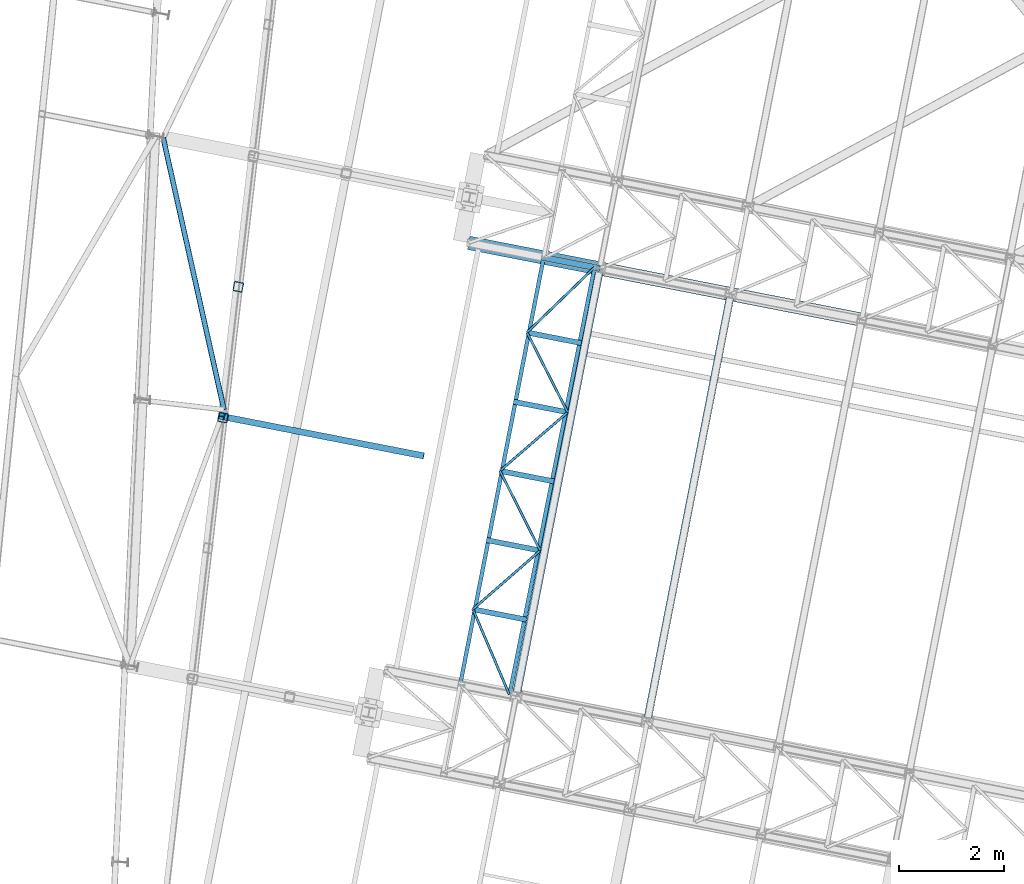
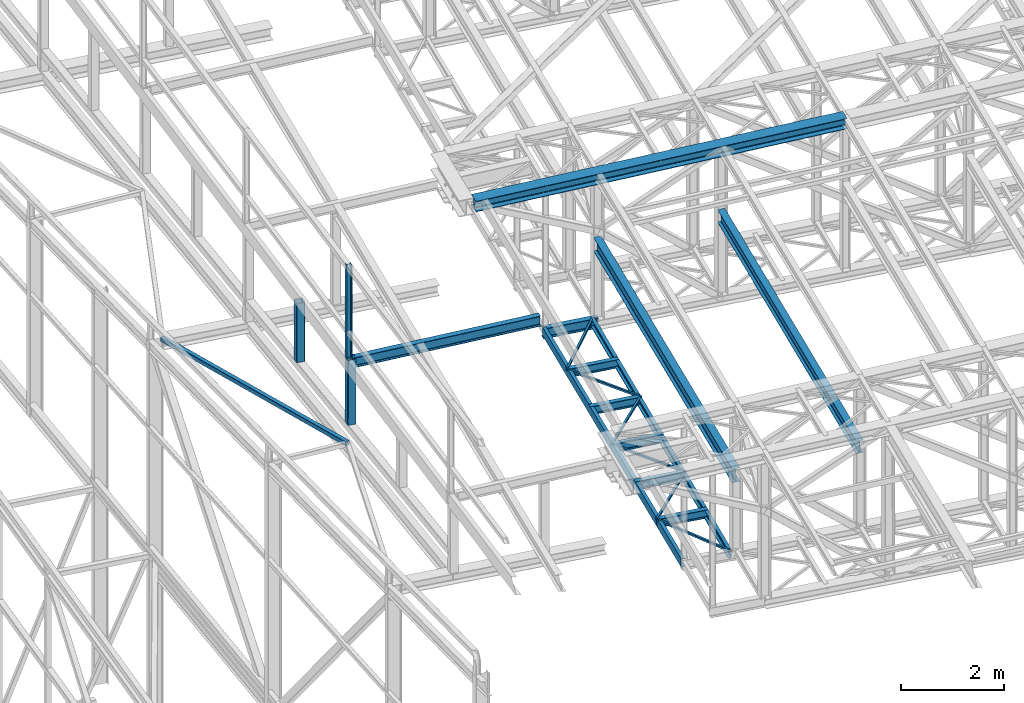
# One storey, part 43 of 215: 22 beams, 22 elements without a shape of their own.
"""IFC2X3 building model written with IfcOpenShell, lengths in millimetres."""

from ifc_helpers import new_model, si_unit, frame, origin_with_axes, origin_2d_with_axis, place, context, subcontext, project, spatial, hollow_rectangle, i_section, u_section, extrude, clip, halfspace, material, type_object, element, aggregate, save


model = new_model("IFC2X3")

# Units and contexts
model_context = context("Model", 3, precision=1e-05, world=origin_with_axes())
body_context = subcontext(model_context, "Body", "Model", "MODEL_VIEW")
ifc_project = project(units=[si_unit("LENGTHUNIT", "METRE", prefix="MILLI"), si_unit("AREAUNIT", "SQUARE_METRE"), si_unit("VOLUMEUNIT", "CUBIC_METRE"), si_unit("MASSUNIT", "GRAM", prefix="KILO"), si_unit("TIMEUNIT", "SECOND"), si_unit("PLANEANGLEUNIT", "RADIAN"), si_unit("SOLIDANGLEUNIT", "STERADIAN"), si_unit("THERMODYNAMICTEMPERATUREUNIT", "DEGREE_CELSIUS"), si_unit("LUMINOUSINTENSITYUNIT", "LUMEN")], contexts=[model_context])

# Site, building, storey
site_placement = place(None, origin_with_axes())
site = spatial("IfcSite", under=ifc_project, at=site_placement, CompositionType="ELEMENT")
building_placement = place(site_placement, origin_with_axes())
building = spatial("IfcBuilding", under=site, at=building_placement, Name="Undefined", CompositionType="ELEMENT")
storey_placement = place(building_placement, origin_with_axes())
storey = spatial("IfcBuildingStorey", under=building, at=storey_placement, Name="Undefined", CompositionType="ELEMENT", Elevation=0.0)

# Assembly, beam
assembly_1_placement = place(storey_placement, origin_with_axes())
assembly_1 = element("IfcElementAssembly", 1, at=assembly_1_placement, inside=storey, Name="Steel Assembly", AssemblyPlace="NOTDEFINED", PredefinedType="RIGID_FRAME")
ifc_material_1 = material(Name="STEEL/S355JR")
beam_type_1 = type_object("IfcBeamType", Name="IPE240", PredefinedType="NOTDEFINED")
beam_1_placement = place(assembly_1_placement, frame((45544.5586696769, 31857.4707559464, 8619.99999999768), z_axis=(0.0, 0.0, 1.0), x_axis=(0.981422409205525, -0.19185946604018, 1.89999991602007e-08)))
beam_1 = element("IfcBeam", 2, at=beam_1_placement, type_object=beam_type_1, material=ifc_material_1, ObjectType="IPE240", context=body_context, shape_type="SweptSolid", body=[
    extrude(i_section(OverallWidth=120.0, OverallDepth=240.0, WebThickness=6.199999809, FlangeThickness=9.800000191, FilletRadius=15.0, at=origin_2d_with_axis()), frame((1125.79486349449, 0.0, 0.0), z_axis=(-1.0, 0.0, 0.0), x_axis=(-6.93889390390723e-18, -1.0, -3.46944695195361e-18)), (0.0, 0.0, 1.0), 1125.8),
])
aggregate(assembly_1, [beam_1])

assembly_2_placement = place(storey_placement, origin_with_axes())
assembly_2 = element("IfcElementAssembly", 3, at=assembly_2_placement, inside=storey, Name="Steel Assembly", AssemblyPlace="NOTDEFINED", PredefinedType="RIGID_FRAME")
ifc_material_2 = material(Name="STEEL/S275JR")
beam_2_placement = place(assembly_2_placement, frame((39390.3962023619, 28832.8524973766, 11886.0187981017), z_axis=(-0.0304080349967745, 0.00594450299936818, 0.999519891893966), x_axis=(0.980951223231219, -0.191767338045201, 0.0309836360073031)))
beam_2 = element("IfcBeam", 4, at=beam_2_placement, type_object=beam_type_1, material=ifc_material_2, Name="TRAVERSE", ObjectType="IPE240", context=body_context, shape_type="SweptSolid", body=[
    extrude(i_section(OverallWidth=120.0, OverallDepth=240.0, WebThickness=6.199999809, FlangeThickness=9.800000191, FilletRadius=15.0, at=origin_2d_with_axis()), frame((3981.40487221962, -1.02714526831027e-13, -1.79136285754903e-12), z_axis=(-1.0, 0.0, 0.0), x_axis=(-6.93889390390723e-18, -1.0, -3.46944695195361e-18)), (0.0, 0.0, 1.0), 3981.4),
])
aggregate(assembly_2, [beam_2])

assembly_3_placement = place(storey_placement, origin_with_axes())
assembly_3 = element("IfcElementAssembly", 5, at=assembly_3_placement, inside=storey, Name="Steel Assembly", AssemblyPlace="NOTDEFINED", PredefinedType="RIGID_FRAME")
beam_type_2 = type_object("IfcBeamType", PredefinedType="NOTDEFINED")
beam_3_placement = place(assembly_3_placement, frame((38329.7469281126, 34132.8784085332, 9619.916786054), z_axis=(0.975916895261586, 0.217524361058308, -0.0164123700043992), x_axis=(0.218066762939199, -0.974796631728206, 0.0471000389868677)))
beam_3 = element("IfcBeam", 6, at=beam_3_placement, type_object=beam_type_2, material=ifc_material_2, context=body_context, shape_type="SweptSolid", body=[
    extrude(hollow_rectangle(XDim=100.0, YDim=100.0, WallThickness=5.0, InnerFilletRadius=5.0, OuterFilletRadius=10.0, at=origin_2d_with_axis()), frame((5318.61377056941, 1.78208410687602e-12, -3.05621988047122e-14), z_axis=(-1.0, 0.0, 0.0), x_axis=(-6.93889390390723e-18, -1.0, -3.46944695195361e-18)), (0.0, 0.0, 1.0), 5318.6),
])
aggregate(assembly_3, [beam_3])

assembly_4_placement = place(storey_placement, origin_with_axes())
assembly_4 = element("IfcElementAssembly", 7, at=assembly_4_placement, inside=storey, Name="Steel Assembly", AssemblyPlace="NOTDEFINED", PredefinedType="RIGID_FRAME")
beam_type_3 = type_object("IfcBeamType", PredefinedType="NOTDEFINED")
beam_4_placement = place(assembly_4_placement, frame((44232.8650283521, 25147.8197383188, 8715.68808127638), z_axis=(0.0, 0.0, -1.0), x_axis=(0.392413519067678, -0.919788905158635, 0.0)))
beam_4 = element("IfcBeam", 8, at=beam_4_placement, type_object=beam_type_3, material=ifc_material_2, context=body_context, shape_type="SweptSolid", body=[
    extrude(hollow_rectangle(XDim=50.0, YDim=50.0, WallThickness=3.0, InnerFilletRadius=3.0, OuterFilletRadius=6.0, at=origin_2d_with_axis()), frame((1768.40075132733, 0.0, 0.0), z_axis=(-1.0, 0.0, 0.0), x_axis=(-6.93889390390723e-18, -1.0, -3.46944695195361e-18)), (0.0, 0.0, 1.0), 1768.4),
])
aggregate(assembly_4, [beam_4])

assembly_5_placement = place(storey_placement, origin_with_axes())
assembly_5 = element("IfcElementAssembly", 9, at=assembly_5_placement, inside=storey, Name="Steel Assembly", AssemblyPlace="NOTDEFINED", PredefinedType="RIGID_FRAME")
beam_5_placement = place(assembly_5_placement, frame((45514.6902231664, 26265.9935730251, 8715.68808127638), z_axis=(0.0, 0.0, -1.0), x_axis=(-0.753573164058399, -0.657364044050946, 0.0)))
beam_5 = element("IfcBeam", 10, at=beam_5_placement, type_object=beam_type_3, material=ifc_material_2, context=body_context, shape_type="SweptSolid", body=[
    extrude(hollow_rectangle(XDim=50.0, YDim=50.0, WallThickness=3.0, InnerFilletRadius=3.0, OuterFilletRadius=6.0, at=origin_2d_with_axis()), frame((1700.99634170737, 3.77697060673333e-13, 0.0), z_axis=(-1.0, 0.0, 0.0), x_axis=(-6.93889390390723e-18, -1.0, -3.46944695195361e-18)), (0.0, 0.0, 1.0), 1701.0),
])
aggregate(assembly_5, [beam_5])

assembly_6_placement = place(storey_placement, origin_with_axes())
assembly_6 = element("IfcElementAssembly", 11, at=assembly_6_placement, inside=storey, Name="Steel Assembly", AssemblyPlace="NOTDEFINED", PredefinedType="RIGID_FRAME")
beam_6_placement = place(assembly_6_placement, frame((44748.3306575184, 27784.5723727106, 8715.68808126931), z_axis=(0.0, 0.0, -1.0), x_axis=(0.450535692998692, -0.892758415997401, 0.0)))
beam_6 = element("IfcBeam", 12, at=beam_6_placement, type_object=beam_type_3, material=ifc_material_2, context=body_context, shape_type="SweptSolid", body=[
    extrude(hollow_rectangle(XDim=50.0, YDim=50.0, WallThickness=3.0, InnerFilletRadius=3.0, OuterFilletRadius=6.0, at=origin_2d_with_axis()), frame((1700.99634170737, 3.77697060673333e-13, 0.0), z_axis=(-1.0, 0.0, 0.0), x_axis=(-6.93889390390723e-18, -1.0, -3.46944695195361e-18)), (0.0, 0.0, 1.0), 1701.0),
])
aggregate(assembly_6, [beam_6])

assembly_7_placement = place(storey_placement, origin_with_axes())
assembly_7 = element("IfcElementAssembly", 13, at=assembly_7_placement, inside=storey, Name="Steel Assembly", AssemblyPlace="NOTDEFINED", PredefinedType="RIGID_FRAME")
beam_7_placement = place(assembly_7_placement, frame((46038.5998007224, 28901.0954779881, 8715.68808126934), z_axis=(0.0, 0.0, -1.0), x_axis=(-0.756184910996357, -0.654357990996849, 0.0)))
beam_7 = element("IfcBeam", 14, at=beam_7_placement, type_object=beam_type_3, material=ifc_material_2, context=body_context, shape_type="SweptSolid", body=[
    extrude(hollow_rectangle(XDim=50.0, YDim=50.0, WallThickness=3.0, InnerFilletRadius=3.0, OuterFilletRadius=6.0, at=origin_2d_with_axis()), frame((1706.28787331128, -1.53483539100752e-12, 0.0), z_axis=(-1.0, 0.0, 0.0), x_axis=(-6.93889390390723e-18, -1.0, -3.46944695195361e-18)), (0.0, 0.0, 1.0), 1706.3),
])
aggregate(assembly_7, [beam_7])

assembly_8_placement = place(storey_placement, origin_with_axes())
assembly_8 = element("IfcElementAssembly", 15, at=assembly_8_placement, inside=storey, Name="Steel Assembly", AssemblyPlace="NOTDEFINED", PredefinedType="RIGID_FRAME")
beam_8_placement = place(assembly_8_placement, frame((45263.7962866848, 30421.3250071021, 8715.68808126225), z_axis=(0.0, 0.0, -1.0), x_axis=(0.454087218065015, -0.89095723712756, 0.0)))
beam_8 = element("IfcBeam", 16, at=beam_8_placement, type_object=beam_type_3, material=ifc_material_2, context=body_context, shape_type="SweptSolid", body=[
    extrude(hollow_rectangle(XDim=50.0, YDim=50.0, WallThickness=3.0, InnerFilletRadius=3.0, OuterFilletRadius=6.0, at=origin_2d_with_axis()), frame((1706.28787331128, -1.53483539100752e-12, 0.0), z_axis=(-1.0, 0.0, 0.0), x_axis=(-6.93889390390723e-18, -1.0, -3.46944695195361e-18)), (0.0, 0.0, 1.0), 1706.3),
])
aggregate(assembly_8, [beam_8])

assembly_9_placement = place(storey_placement, origin_with_axes())
assembly_9 = element("IfcElementAssembly", 17, at=assembly_9_placement, inside=storey, Name="Steel Assembly", AssemblyPlace="NOTDEFINED", PredefinedType="RIGID_FRAME")
beam_9_placement = place(assembly_9_placement, frame((46548.8650694623, 31661.1320994037, 8715.68808126218), z_axis=(0.0, 0.0, -1.0), x_axis=(-0.71966696784498, -0.69431941885044, 0.0)))
beam_9 = element("IfcBeam", 18, at=beam_9_placement, type_object=beam_type_3, material=ifc_material_2, context=body_context, shape_type="SweptSolid", body=[
    extrude(hollow_rectangle(XDim=50.0, YDim=50.0, WallThickness=3.0, InnerFilletRadius=3.0, OuterFilletRadius=6.0, at=origin_2d_with_axis()), frame((1785.64369413783, -1.81898940354586e-12, 0.0), z_axis=(-1.0, 0.0, 0.0), x_axis=(-6.93889390390723e-18, -1.0, -3.46944695195361e-18)), (0.0, 0.0, 1.0), 1785.6),
])
aggregate(assembly_9, [beam_9])

assembly_10_placement = place(storey_placement, origin_with_axes())
assembly_10 = element("IfcElementAssembly", 19, at=assembly_10_placement, inside=storey, Name="Steel Assembly", AssemblyPlace="NOTDEFINED", PredefinedType="RIGID_FRAME")
beam_type_4 = type_object("IfcBeamType", Name="UPN200", PredefinedType="NOTDEFINED")
beam_10_placement = place(assembly_10_placement, frame((45581.3555770996, 31850.2772905966, 8640.68808129229), z_axis=(0.0, 0.0, -1.0), x_axis=(-0.191860814904866, -0.981422145513357, 0.0)))
beam_10 = element("IfcBeam", 20, at=beam_10_placement, type_object=beam_type_4, material=ifc_material_2, ObjectType="UPN200", context=body_context, shape_type="SweptSolid", body=[
    extrude(u_section(Depth=200.0, FlangeWidth=75.0, WebThickness=8.5, FlangeThickness=11.5, FilletRadius=11.5, EdgeRadius=6.0, FlangeSlope=0.0798299857122373, at=origin_2d_with_axis()), frame((8299.99520183324, 7.50632875861727e-12, -1.81898940354586e-12), z_axis=(-1.0, 0.0, 0.0), x_axis=(-6.93889390390723e-18, -1.0, -3.46944695195361e-18)), (0.0, 0.0, 1.0), 8300.0),
])
aggregate(assembly_10, [beam_10])

assembly_11_placement = place(storey_placement, origin_with_axes())
assembly_11 = element("IfcElementAssembly", 21, at=assembly_11_placement, inside=storey, Name="Steel Assembly", AssemblyPlace="NOTDEFINED", PredefinedType="RIGID_FRAME")
beam_11_placement = place(assembly_11_placement, frame((44930.9789326412, 23520.4412726233, 8640.6880812835), z_axis=(0.0, 0.0, -1.0), x_axis=(0.195171766899161, 0.980769076493269, 0.0)))
beam_11 = element("IfcBeam", 22, at=beam_11_placement, type_object=beam_type_4, material=ifc_material_2, ObjectType="UPN200", context=body_context, shape_type="SweptSolid", body=[
    extrude(u_section(Depth=200.0, FlangeWidth=75.0, WebThickness=8.5, FlangeThickness=11.5, FilletRadius=11.5, EdgeRadius=6.0, FlangeSlope=0.0798299857122373, at=origin_2d_with_axis()), frame((8299.89954560705, -2.3036848944022e-13, 0.0), z_axis=(-1.0, 0.0, 0.0), x_axis=(-6.93889390390723e-18, -1.0, -3.46944695195361e-18)), (0.0, 0.0, 1.0), 8299.9),
])
aggregate(assembly_11, [beam_11])

assembly_12_placement = place(storey_placement, origin_with_axes())
assembly_12 = element("IfcElementAssembly", 23, at=assembly_12_placement, inside=storey, Name="Steel Assembly", AssemblyPlace="NOTDEFINED", PredefinedType="RIGID_FRAME")
beam_type_5 = type_object("IfcBeamType", PredefinedType="NOTDEFINED")
beam_12_placement = place(assembly_12_placement, frame((39761.4727832382, 31291.9300104335, 11736.8686248737), z_axis=(-0.981422412140383, 0.191859451027444, 0.0), x_axis=(0.0, 0.0, -1.0)))
beam_12 = element("IfcBeam", 24, at=beam_12_placement, type_object=beam_type_5, material=ifc_material_2, Name="MONTANT", context=body_context, shape_type="Clipping", body=[
    clip(extrude(hollow_rectangle(XDim=180.0, YDim=180.0, WallThickness=8.0, InnerFilletRadius=12.0, OuterFilletRadius=20.0, at=origin_2d_with_axis()), frame((1405.59182170057, 0.0, 0.0), z_axis=(-1.0, 0.0, 0.0), x_axis=(-6.93889390390723e-18, -1.0, -3.46944695195361e-18)), (0.0, 0.0, 1.0), 1405.6), halfspace(frame((1408.63968319935, -151.148204456535, 101.765882453423), z_axis=(-0.99875033817135, -0.0498277907891155, 0.00386694552461437), x_axis=(0.0, -0.0773735506072624, -0.997002173350904)), True)),
])
aggregate(assembly_12, [beam_12])

assembly_13_placement = place(storey_placement, origin_with_axes())
assembly_13 = element("IfcElementAssembly", 25, at=assembly_13_placement, inside=storey, Name="Steel Assembly", AssemblyPlace="NOTDEFINED", PredefinedType="RIGID_FRAME")
beam_13_placement = place(assembly_13_placement, frame((39472.4782659299, 28801.0394779885, 11976.1490847472), z_axis=(-0.981422412140383, 0.191859451027444, 0.0), x_axis=(0.0, 0.0, -1.0)))
beam_13 = element("IfcBeam", 26, at=beam_13_placement, type_object=beam_type_5, material=ifc_material_2, Name="MONTANT", context=body_context, shape_type="Clipping", body=[
    clip(clip(extrude(hollow_rectangle(XDim=180.0, YDim=180.0, WallThickness=8.0, InnerFilletRadius=12.0, OuterFilletRadius=20.0, at=origin_2d_with_axis()), frame((1514.50469071019, 0.0, 0.0), z_axis=(-1.0, 0.0, 0.0), x_axis=(-6.93889390390723e-18, -1.0, -3.46944695195361e-18)), (0.0, 0.0, 1.0), 1551.6), halfspace(frame((1523.69820856424, -176.206894575029, 103.965464390218), z_axis=(-0.99875033817135, -0.0498277907891155, 0.00386694552461437), x_axis=(0.0, -0.0773735506072624, -0.997002173350904)), True)), halfspace(frame((-37.4295460500798, 157.566234099264, 84.2397413081562), z_axis=(0.999997034433376, 0.00242814009745113, -0.000187776786755893), x_axis=(0.0, -0.0771033742924094, -0.997023103881111)), True)),
])
aggregate(assembly_13, [beam_13])

assembly_14_placement = place(storey_placement, origin_with_axes())
assembly_14 = element("IfcElementAssembly", 27, at=assembly_14_placement, inside=storey, Name="Steel Assembly", AssemblyPlace="NOTDEFINED", PredefinedType="RIGID_FRAME")
beam_type_6 = type_object("IfcBeamType", Name="HEA120", PredefinedType="NOTDEFINED")
beam_14_placement = place(assembly_14_placement, frame((39438.9912074627, 28823.4326067669, 14219.9969931652), z_axis=(0.981422409205525, -0.19185946604018, 1.89999991602007e-08), x_axis=(0.0, 0.0, -1.0)))
beam_14 = element("IfcBeam", 28, at=beam_14_placement, type_object=beam_type_6, material=ifc_material_2, ObjectType="HEA120", context=body_context, shape_type="SweptSolid", body=[
    extrude(i_section(OverallWidth=120.0, OverallDepth=114.0, WebThickness=5.0, FlangeThickness=8.0, FilletRadius=12.0, at=origin_2d_with_axis()), frame((2213.77432796867, 0.0, -7.32476481865318e-21), z_axis=(-1.0, 0.0, 0.0), x_axis=(-6.93889390390723e-18, -1.0, -3.46944695195361e-18)), (0.0, 0.0, 1.0), 2213.8),
])
aggregate(assembly_14, [beam_14])

assembly_15_placement = place(storey_placement, origin_with_axes())
assembly_15 = element("IfcElementAssembly", 29, at=assembly_15_placement, inside=storey, Name="Steel Assembly", AssemblyPlace="NOTDEFINED", PredefinedType="RIGID_FRAME")
beam_type_7 = type_object("IfcBeamType", Name="IPE300", PredefinedType="NOTDEFINED")
beam_15_placement = place(assembly_15_placement, frame((47553.2305736091, 23007.6851341911, 10567.0900002997), z_axis=(0.0, 0.0, 1.0), x_axis=(0.191859470081235, 0.981422408415534, 0.0)))
beam_15 = element("IfcBeam", 30, at=beam_15_placement, type_object=beam_type_7, material=ifc_material_2, Name="SUPPORT", ObjectType="IPE300", context=body_context, shape_type="SweptSolid", body=[
    extrude(i_section(OverallWidth=150.0, OverallDepth=300.0, WebThickness=7.099999905, FlangeThickness=10.69999981, FilletRadius=15.0, at=origin_2d_with_axis()), frame((8299.99526300685, 1.47838788079098e-11, -1.71639879146031e-21), z_axis=(-1.0, 0.0, 0.0), x_axis=(-6.93889390390723e-18, -1.0, -3.46944695195361e-18)), (0.0, 0.0, 1.0), 8300.0),
])
aggregate(assembly_15, [beam_15])

assembly_16_placement = place(storey_placement, origin_with_axes())
assembly_16 = element("IfcElementAssembly", 31, at=assembly_16_placement, inside=storey, Name="Steel Assembly", AssemblyPlace="NOTDEFINED", PredefinedType="RIGID_FRAME")
beam_type_8 = type_object("IfcBeamType", Name="IPE200", PredefinedType="NOTDEFINED")
beam_16_placement = place(assembly_16_placement, frame((45252.7354343881, 24948.4426205438, 8640.68808127995), z_axis=(0.0, 0.0, -1.0), x_axis=(-0.981422136295317, 0.191860862057732, 0.0)))
beam_16 = element("IfcBeam", 32, at=beam_16_placement, type_object=beam_type_8, material=ifc_material_2, ObjectType="IPE200", context=body_context, shape_type="SweptSolid", body=[
    extrude(i_section(OverallWidth=100.0, OverallDepth=200.0, WebThickness=5.599999905, FlangeThickness=8.5, FilletRadius=12.0, at=origin_2d_with_axis()), frame((1039.17605831378, -7.27595761418343e-12, -1.81898940354586e-12), z_axis=(-1.0, 0.0, 0.0), x_axis=(-6.93889390390723e-18, -1.0, -3.46944695195361e-18)), (0.0, 0.0, 1.0), 1039.2),
])
aggregate(assembly_16, [beam_16])

assembly_17_placement = place(storey_placement, origin_with_axes())
assembly_17 = element("IfcElementAssembly", 33, at=assembly_17_placement, inside=storey, Name="Steel Assembly", AssemblyPlace="NOTDEFINED", PredefinedType="RIGID_FRAME")
beam_17_placement = place(assembly_17_placement, frame((45514.6902231661, 26265.9935730253, 8640.68808127643), z_axis=(0.0, 0.0, -1.0), x_axis=(-0.981422136295317, 0.191860862057732, 0.0)))
beam_17 = element("IfcBeam", 34, at=beam_17_placement, type_object=beam_type_8, material=ifc_material_2, ObjectType="IPE200", context=body_context, shape_type="SweptSolid", body=[
    extrude(i_section(OverallWidth=100.0, OverallDepth=200.0, WebThickness=5.599999905, FlangeThickness=8.5, FilletRadius=12.0, at=origin_2d_with_axis()), frame((1043.47795243299, 0.0, 1.81898940354586e-12), z_axis=(-1.0, 0.0, 0.0), x_axis=(-6.93889390390723e-18, -1.0, -3.46944695195361e-18)), (0.0, 0.0, 1.0), 1043.5),
])
aggregate(assembly_17, [beam_17])

assembly_18_placement = place(storey_placement, origin_with_axes())
assembly_18 = element("IfcElementAssembly", 35, at=assembly_18_placement, inside=storey, Name="Steel Assembly", AssemblyPlace="NOTDEFINED", PredefinedType="RIGID_FRAME")
beam_18_placement = place(assembly_18_placement, frame((45776.6450119442, 27583.5445255068, 8640.68808127291), z_axis=(0.0, 0.0, -1.0), x_axis=(-0.981422136295317, 0.191860862057732, 0.0)))
beam_18 = element("IfcBeam", 36, at=beam_18_placement, type_object=beam_type_8, material=ifc_material_2, ObjectType="IPE200", context=body_context, shape_type="SweptSolid", body=[
    extrude(i_section(OverallWidth=100.0, OverallDepth=200.0, WebThickness=5.599999905, FlangeThickness=8.5, FilletRadius=12.0, at=origin_2d_with_axis()), frame((1047.77984655224, 2.90817327595128e-14, 1.81898940354586e-12), z_axis=(-1.0, 0.0, 0.0), x_axis=(-6.93889390390723e-18, -1.0, -3.46944695195361e-18)), (0.0, 0.0, 1.0), 1047.8),
])
aggregate(assembly_18, [beam_18])

assembly_19_placement = place(storey_placement, origin_with_axes())
assembly_19 = element("IfcElementAssembly", 37, at=assembly_19_placement, inside=storey, Name="Steel Assembly", AssemblyPlace="NOTDEFINED", PredefinedType="RIGID_FRAME")
beam_19_placement = place(assembly_19_placement, frame((46038.5998007222, 28901.0954779883, 8640.6880812694), z_axis=(0.0, 0.0, -1.0), x_axis=(-0.981422136295317, 0.191860862057732, 0.0)))
beam_19 = element("IfcBeam", 38, at=beam_19_placement, type_object=beam_type_8, material=ifc_material_2, ObjectType="IPE200", context=body_context, shape_type="SweptSolid", body=[
    extrude(i_section(OverallWidth=100.0, OverallDepth=200.0, WebThickness=5.599999905, FlangeThickness=8.5, FilletRadius=12.0, at=origin_2d_with_axis()), frame((1052.08174068533, 0.0, 0.0), z_axis=(-1.0, 0.0, 0.0), x_axis=(-6.93889390390723e-18, -1.0, -3.46944695195361e-18)), (0.0, 0.0, 1.0), 1052.1),
])
aggregate(assembly_19, [beam_19])

assembly_20_placement = place(storey_placement, origin_with_axes())
assembly_20 = element("IfcElementAssembly", 39, at=assembly_20_placement, inside=storey, Name="Steel Assembly", AssemblyPlace="NOTDEFINED", PredefinedType="RIGID_FRAME")
beam_20_placement = place(assembly_20_placement, frame((46300.5545894992, 30218.64643047, 8640.68808126587), z_axis=(0.0, 0.0, -1.0), x_axis=(-0.981422136295317, 0.191860862057732, 0.0)))
beam_20 = element("IfcBeam", 40, at=beam_20_placement, type_object=beam_type_8, material=ifc_material_2, ObjectType="IPE200", context=body_context, shape_type="SweptSolid", body=[
    extrude(i_section(OverallWidth=100.0, OverallDepth=200.0, WebThickness=5.599999905, FlangeThickness=8.5, FilletRadius=12.0, at=origin_2d_with_axis()), frame((1056.38363478965, -2.93205358545171e-14, 0.0), z_axis=(-1.0, 0.0, 0.0), x_axis=(-6.93889390390723e-18, -1.0, -3.46944695195361e-18)), (0.0, 0.0, 1.0), 1056.4),
])
aggregate(assembly_20, [beam_20])

assembly_21_placement = place(storey_placement, origin_with_axes())
assembly_21 = element("IfcElementAssembly", 41, at=assembly_21_placement, inside=storey, Name="Steel Assembly", AssemblyPlace="NOTDEFINED", PredefinedType="RIGID_FRAME")
beam_type_9 = type_object("IfcBeamType", Name="IPE330", PredefinedType="NOTDEFINED")
beam_21_placement = place(assembly_21_placement, frame((45057.0064680392, 23495.6749949446, 10473.250000477), z_axis=(0.0, 0.0, 1.0), x_axis=(0.191859470081235, 0.981422408415534, 0.0)))
beam_21 = element("IfcBeam", 42, at=beam_21_placement, type_object=beam_type_9, material=ifc_material_2, Name="SUPPORT", ObjectType="IPE330", context=body_context, shape_type="SweptSolid", body=[
    extrude(i_section(OverallWidth=160.0, OverallDepth=330.0, WebThickness=7.5, FlangeThickness=11.5, FilletRadius=18.0, at=origin_2d_with_axis()), frame((8299.99526300685, 1.47838788079098e-11, -1.71639879146031e-21), z_axis=(-1.0, 0.0, 0.0), x_axis=(-6.93889390390723e-18, -1.0, -3.46944695195361e-18)), (0.0, 0.0, 1.0), 8300.0),
])
aggregate(assembly_21, [beam_21])

assembly_22_placement = place(storey_placement, origin_with_axes())
assembly_22 = element("IfcElementAssembly", 43, at=assembly_22_placement, inside=storey, Name="Steel Assembly", AssemblyPlace="NOTDEFINED", PredefinedType="RIGID_FRAME")
beam_type_10 = type_object("IfcBeamType", Name="HEA260", PredefinedType="NOTDEFINED")
beam_22_placement = place(assembly_22_placement, frame((44157.0158991177, 32128.7231656783, 12006.4278258793), z_axis=(-0.0304080349967745, 0.00594450299936818, 0.999519891893966), x_axis=(0.980951223231219, -0.191767338045201, 0.0309836360073031)))
beam_22 = element("IfcBeam", 44, at=beam_22_placement, type_object=beam_type_10, material=ifc_material_1, Name="SUP", ObjectType="HEA260", context=body_context, shape_type="SweptSolid", body=[
    extrude(i_section(OverallWidth=260.0, OverallDepth=250.0, WebThickness=7.5, FlangeThickness=12.5, FilletRadius=24.0, at=origin_2d_with_axis()), frame((7634.09340299227, -5.54373729838705e-14, -2.64860820879407e-14), z_axis=(-1.0, 0.0, 0.0), x_axis=(-6.93889390390723e-18, -1.0, -3.46944695195361e-18)), (0.0, 0.0, 1.0), 7634.1),
])
aggregate(assembly_22, [beam_22])

save(model, "model.ifc")
